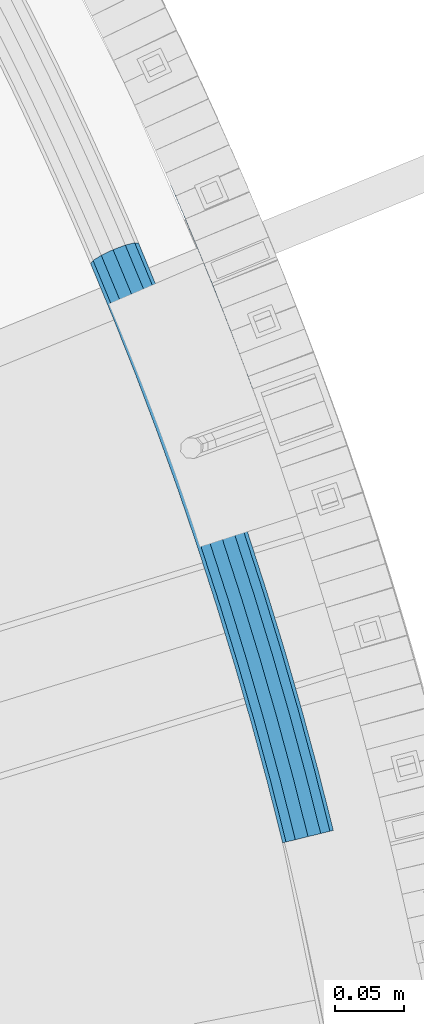
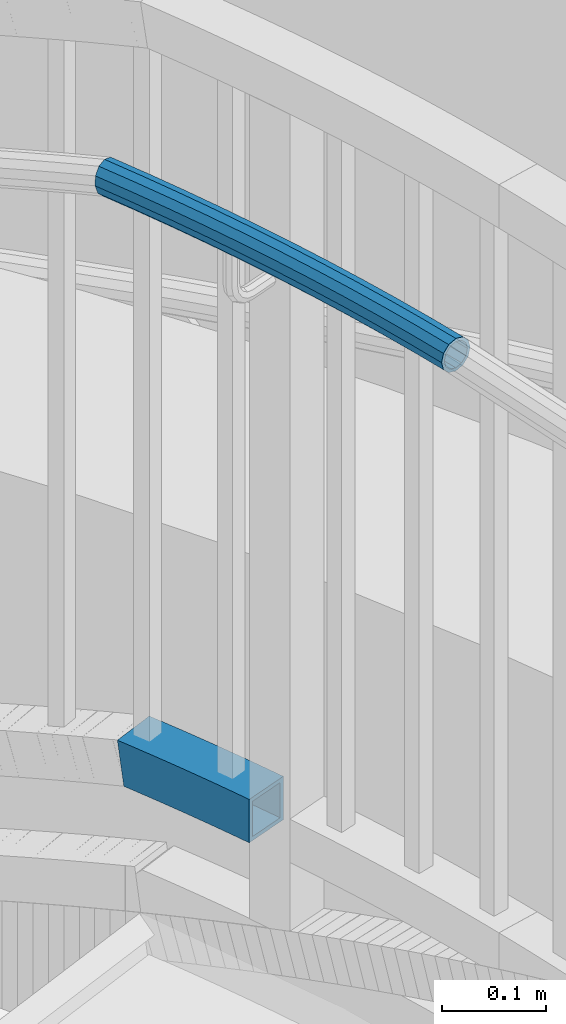
# One storey, part 509 of 975: 2 beams.
"""IFC2X3 building model written with IfcOpenShell, lengths in millimetres."""

from ifc_helpers import new_model, si_unit, frame, origin_with_axes, place, context, subcontext, project, spatial, faceted_brep, material, type_object, element, save


model = new_model("IFC2X3")

# Units and contexts
model_context = context("Model", 3, precision=1e-05, world=origin_with_axes())
body_context = subcontext(model_context, "Body", "Model", "MODEL_VIEW")
ifc_project = project(units=[si_unit("LENGTHUNIT", "METRE", prefix="MILLI"), si_unit("AREAUNIT", "SQUARE_METRE"), si_unit("VOLUMEUNIT", "CUBIC_METRE"), si_unit("MASSUNIT", "GRAM", prefix="KILO"), si_unit("TIMEUNIT", "SECOND"), si_unit("PLANEANGLEUNIT", "RADIAN"), si_unit("SOLIDANGLEUNIT", "STERADIAN"), si_unit("THERMODYNAMICTEMPERATUREUNIT", "DEGREE_CELSIUS"), si_unit("LUMINOUSINTENSITYUNIT", "LUMEN")], contexts=[model_context])

# Site, building, storey
site_placement = place(None, origin_with_axes())
site = spatial("IfcSite", under=ifc_project, at=site_placement, CompositionType="ELEMENT")
building_placement = place(site_placement, origin_with_axes())
building = spatial("IfcBuilding", under=site, at=building_placement, Name="Undefined", CompositionType="ELEMENT")
storey_placement = place(building_placement, origin_with_axes())
storey = spatial("IfcBuildingStorey", under=building, at=storey_placement, Name="Undefined", CompositionType="ELEMENT", Elevation=0.0)

# Beams
ifc_material = material()
beam_type_1 = type_object("IfcBeamType", PredefinedType="NOTDEFINED")
beam_1_placement = place(storey_placement, frame((37300.2363106744, 4493.54942107497, 3028.95), z_axis=(0.0, 0.0, 1.0), x_axis=(0.315248531112646, -0.949009148339108, 0.0)))
element("IfcBeam", 1, at=beam_1_placement, inside=storey, type_object=beam_type_1, material=ifc_material, Name="HANDRAIL", context=body_context, shape_type="Brep", body=[
    faceted_brep([(43.9662384109333, 19.7516310923238, -9.52500000000009), (44.4177076830847, 12.7934782196535, -16.4977839420935), (4.88784464295168, 9.90696300108539, -16.4977839420935), (3.21381363590353, 16.7758430358954, -9.52500000000009), (43.8009891883012, 22.2984918071379, 0.0), (1.49115918698317, 19.2089802631526, 0.0), (43.9662384109333, 19.7516310923238, 9.52500000000009), (0.181465164617293, 16.5544175277537, 9.52500000000009), (44.4177076830847, 12.7934782196535, 16.4977839420935), (-0.364336975573679, 9.52344277088559, 16.4977839420935), (45.034426177871, 3.2884646321836, 19.0500000000002), (-3.63797880709171e-12, 3.63797880709171e-12, 19.0500000000002), (45.6511446726563, -6.21654895529355, 16.4977839420935), (1.17685231783889, -9.46411198346323, 16.4977839420935), (46.1026139448077, -13.1747018279639, 9.52500000000009), (2.85088332488613, -16.3329920182732, 9.52500000000009), (46.2678631674435, -15.7215625427707, 0.0), (4.57353777380649, -18.7661292455377, 0.0), (46.1026139448077, -13.1747018279639, -9.52500000000009), (5.88323179617146, -16.1115665101388, -9.52500000000009), (45.6511446726563, -6.21654895529355, -16.4977839420935), (6.42903393636243, -9.08059175326343, -16.4977839420935), (45.034426177871, 3.2884646321836, -19.0500000000002), (6.06469695168289, 0.442851016952773, -19.0500000000002), (89.6535286661638, 15.3608104653613, -16.4977839420935), (90.1162091780316, 5.84705454333744, -19.0500000000002), (90.5788896899039, -3.66670137867914, -16.4977839420935), (90.9175953322629, -10.6312540844083, -9.52500000000009), (91.0415702017717, -13.180457300703, 0.0), (90.9175953322629, -10.6312540844083, 9.52500000000009), (90.5788896899039, -3.66670137867914, 16.4977839420935), (90.1162091780316, 5.84705454333744, 19.0500000000002), (89.6535286661638, 15.3608104653613, 16.4977839420935), (89.314823023803, 22.3253631710977, 9.52500000000009), (89.1908481542932, 24.8745663873851, 0.0), (89.314823023803, 22.3253631710977, -9.52500000000009), (134.699146393385, 24.1642257241328, -9.52500000000009), (134.92499953809, 17.1951005092851, -16.4977839420935), (135.23352067128, 7.67509842366417, -19.0500000000002), (135.542041804473, -1.84490366196405, -16.4977839420935), (135.767894949178, -8.81402887678996, -9.52500000000009), (135.850562937663, -11.364905747585, 0.0), (135.767894949178, -8.81402887678996, 9.52500000000009), (135.542041804473, -1.84490366196405, 16.4977839420935), (135.23352067128, 7.67509842366417, 19.0500000000002), (134.92499953809, 17.1951005092851, 16.4977839420935), (134.699146393385, 24.1642257241328, 9.52500000000009), (134.6164784049, 26.7151025949133, 0.0), (180.065961394015, 27.8196175191697, 0.0), (180.107300811473, 25.2677362800023, -9.52500000000009), (180.220242200318, 18.2958670797234, -16.4977839420935), (180.374523006625, 8.77211664028437, -19.0500000000002), (180.52880381293, -0.751633799154661, -16.4977839420935), (180.641745201778, -7.72350299943355, -9.52500000000009), (180.683084619236, -10.2753842385937, 0.0), (180.641745201778, -7.72350299943355, 9.52500000000009), (180.52880381293, -0.751633799154661, 16.4977839420935), (180.374523006625, 8.77211664028437, 19.0500000000002), (180.220242200318, 18.2958670797234, 16.4977839420935), (180.107300811473, 25.2677362800023, 9.52500000000009), (225.527372317183, 25.6356053052223, 9.52500000000009), (225.527372317182, 28.187821363128, 0.0), (225.527372317183, 25.6356053052223, -9.52500000000009), (225.527372317186, 18.6628213631193, -16.4977839420935), (225.52737231719, 9.13782136313239, -19.0500000000002), (225.527372317194, -0.387178636869066, -16.4977839420935), (225.5273723172, -7.35996257895749, -9.52500000000009), (225.5273723172, -9.91217863685597, 0.0), (225.5273723172, -7.35996257895749, 9.52500000000009), (225.527372317194, -0.387178636869066, 16.4977839420935), (225.52737231719, 9.13782136313239, 19.0500000000002), (225.527372317186, 18.6628213631193, 16.4977839420935), (270.834502434054, 18.295867079898, 16.4977839420935), (270.947443822894, 25.2677362801696, 9.52500000000009), (270.988783240348, 27.8196175193298, 0.0), (270.947443822894, 25.2677362801696, -9.52500000000009), (270.834502434054, 18.295867079898, -16.4977839420935), (270.680221627757, 8.77211664045899, -19.0500000000002), (270.525940821462, -0.751633798980038, -16.4977839420935), (270.41299943262, -7.7235029992662, -9.52500000000009), (270.371660015167, -10.2753842384263, 0.0), (270.41299943262, -7.7235029992662, 9.52500000000009), (270.525940821462, -0.751633798980038, 16.4977839420935), (270.680221627757, 8.77211664045899, 19.0500000000002), (315.821223963102, 7.67509842401341, 19.0500000000002), (316.129745096284, 17.1951005096416, 16.4977839420935), (316.355598240983, 24.1642257244748, 9.52500000000009), (316.438266229466, 26.7151025952626, 0.0), (316.355598240983, 24.1642257244748, -9.52500000000009), (316.129745096284, 17.1951005096416, -16.4977839420935), (315.821223963102, 7.67509842401341, -19.0500000000002), (315.51270282992, -1.84490366161481, -16.4977839420935), (315.286849685222, -8.81402887645527, -9.52500000000009), (315.204181696738, -11.364905747243, 0.0), (315.286849685222, -8.81402887645527, 9.52500000000009), (315.51270282992, -1.84490366161481, 16.4977839420935), (360.475854944491, -3.66670137816982, 16.4977839420935), (360.938535456352, 5.8470545438613, 19.0500000000002), (361.401215968212, 15.3608104658852, 16.4977839420935), (361.739921610567, 22.3253631716143, 9.52500000000009), (361.863896480075, 24.8745663879163, 0.0), (361.739921610567, 22.3253631716143, -9.52500000000009), (361.401215968212, 15.3608104658852, -16.4977839420935), (360.938535456352, 5.8470545438613, -19.0500000000002), (360.475854944491, -3.66670137816982, -16.4977839420935), (360.137149302138, -10.6312540838917, -9.52500000000009), (360.013174432632, -13.1804573001864, 0.0), (360.137149302138, -10.6312540838917, 9.52500000000009), (404.952130689596, -13.1747018272727, 9.52500000000009), (405.40359996174, -6.21654895460961, 16.4977839420935), (406.020318456517, 3.28846463287482, 19.0500000000002), (406.637036951293, 12.793478220352, 16.4977839420935), (407.088506223437, 19.751631093015, 9.52500000000009), (407.25375544607, 22.2984918078291, 0.0), (407.088506223437, 19.751631093015, -9.52500000000009), (406.637036951293, 12.793478220352, -16.4977839420935), (406.020318456517, 3.28846463287482, -19.0500000000002), (405.40359996174, -6.21654895460961, -16.4977839420935), (404.952130689596, -13.1747018272727, -9.52500000000009), (404.786881466963, -15.7215625420868, 0.0), (449.513555301939, -18.9875547506308, 0.0), (449.720035520446, -16.4437047696847, 9.52500000000009), (450.284149968164, -9.49377737488248, 16.4977839420935), (451.054744634393, 8.65838956087828e-10, 19.0500000000002), (451.825339300621, 9.49377737662144, 16.4977839420935), (452.38945374834, 16.4437047714164, 9.52500000000009), (452.595933966847, 18.9875547523698, 0.0), (452.38945374834, 16.4437047714164, -9.52500000000009), (451.825339300621, 9.49377737662144, -16.4977839420935), (451.054744634393, 8.65838956087828e-10, -19.0500000000002), (450.284149968164, -9.49377737488248, -16.4977839420935), (449.720035520446, -16.4437047696847, -9.52500000000009), (45.896097643199, -9.99182297899824, -7.68350000000009), (46.0293986827919, -12.046290622282, 0.0), (90.862667070518, -9.50180501085561, 0.0), (90.7626606757785, -7.44544774971291, -7.68350000000009), (135.731268099496, -7.68383827447542, 0.0), (135.664582588784, -5.62613093203254, -7.68350000000009), (180.62342937413, -6.59286740201787, 0.0), (180.59008224405, -4.53434986908542, -7.68350000000009), (225.527372317198, -6.22917863686598, 0.0), (225.527372317197, -4.17039101682167, -7.68350000000009), (270.431315260268, -6.59286740183597, 0.0), (270.464662390348, -4.53434986891079, -7.68350000000009), (315.323476534903, -7.68383827412617, 0.0), (315.390162045612, -5.62613093169784, -7.68350000000009), (360.192077563884, -9.50180501033901, 0.0), (360.29208395862, -7.44544774919632, -7.68350000000009), (405.158646991201, -9.99182297830703, -7.68350000000009), (405.025345951611, -12.0462906215835, 0.0), (449.81151857288, -15.3166274986797, 0.0), (449.978079282476, -13.2645885140373, -7.68350000000009), (360.29208395862, -7.44544774919632, 7.68350000000009), (405.158646991201, -9.99182297830703, 7.68350000000009), (315.390162045612, -5.62613093169784, 7.68350000000009), (270.464662390348, -4.53434986891079, 7.68350000000009), (225.527372317197, -4.17039101682167, 7.68350000000009), (180.59008224405, -4.53434986908542, 7.68350000000009), (135.664582588784, -5.62613093203254, 7.68350000000009), (90.7626606757785, -7.44544774971291, 7.68350000000009), (45.896097643199, -9.99182297899824, 7.68350000000009), (45.5319124303314, -4.37891299505281, 13.3082123799554), (90.489438124273, -1.82737523376272, 13.3082123799554), (135.482394385389, -0.00436992540198844, 13.3082123799554), (180.498976190377, 1.08962461914052, 13.3082123799554), (225.527372317193, 1.4543213631332, 13.3082123799554), (270.555768444013, 1.08962461930787, 13.3082123799554), (315.572350249003, -0.00436992506001843, 13.3082123799554), (360.565306510119, -1.82737523324613, 13.3082123799554), (405.522832204065, -4.37891299435432, 13.3082123799554), (360.938535456352, 5.8470545438613, 15.3670000000002), (406.020318456517, 3.28846463287482, 15.3670000000002), (315.821223963102, 7.67509842401341, 15.3670000000002), (270.680221627757, 8.77211664045899, 15.3670000000002), (225.52737231719, 9.13782136313239, 15.3670000000002), (180.374523006625, 8.77211664028437, 15.3670000000002), (135.23352067128, 7.67509842366417, 15.3670000000002), (90.1162091780316, 5.84705454333744, 15.3670000000002), (45.034426177871, 3.2884646321836, 15.3670000000002), (44.5369399254096, 10.9558422594055, 13.3082123799554), (89.7429802317911, 13.5214843204376, 13.3082123799554), (134.984646957176, 15.3545667727376, 13.3082123799554), (180.250069822872, 16.4546086614282, 13.3082123799554), (225.527372317187, 16.8213213631243, 13.3082123799554), (270.804674811504, 16.4546086616101, 13.3082123799554), (316.070097677202, 15.3545667730796, 13.3082123799554), (361.311764402586, 13.5214843209615, 13.3082123799554), (406.517804708972, 10.9558422601112, 13.3082123799554), (361.584986954084, 19.1395568369117, 7.68350000000009), (406.881989921833, 16.5687522440494, 7.68350000000009), (316.252285880592, 20.9763277797247, 7.68350000000009), (270.895780865169, 22.0785831498288, 7.68350000000009), (225.527372317184, 22.4460337430792, 7.68350000000009), (180.158963769201, 22.0785831496542, 7.68350000000009), (134.802458753778, 20.9763277793681, 7.68350000000009), (89.4697576802873, 19.1395568363951, 7.68350000000009), (44.172754712542, 16.5687522433509, 7.68350000000009), (44.0394536729491, 18.6232198866419, 0.0), (89.3697512855506, 21.195914097545, 0.0), (134.735773243067, 23.0340351218038, 0.0), (180.125616639119, 24.1371006825793, 0.0), (225.527372317186, 24.5048213631235, 0.0), (270.929127995248, 24.137100682754, 0.0), (316.318971391301, 23.0340351221457, 0.0), (361.684993348822, 21.1959140980689, 0.0), (407.015290961423, 18.6232198873404, 0.0), (361.584986954084, 19.1395568369117, -7.68350000000009), (406.881989921833, 16.5687522440494, -7.68350000000009), (316.252285880592, 20.9763277797247, -7.68350000000009), (270.895780865169, 22.0785831498288, -7.68350000000009), (225.527372317184, 22.4460337430792, -7.68350000000009), (180.158963769201, 22.0785831496542, -7.68350000000009), (134.802458753778, 20.9763277793681, -7.68350000000009), (89.4697576802873, 19.1395568363951, -7.68350000000009), (44.172754712542, 16.5687522433509, -7.68350000000009), (44.5369399254096, 10.9558422594055, -13.3082123799554), (89.7429802317911, 13.5214843204376, -13.3082123799554), (134.984646957176, 15.3545667727376, -13.3082123799554), (180.250069822872, 16.4546086614282, -13.3082123799554), (225.527372317187, 16.8213213631243, -13.3082123799554), (270.804674811504, 16.4546086616101, -13.3082123799554), (316.070097677202, 15.3545667730796, -13.3082123799554), (361.311764402586, 13.5214843209615, -13.3082123799554), (406.517804708972, 10.9558422601112, -13.3082123799554), (360.938535456352, 5.8470545438613, -15.3670000000002), (406.020318456517, 3.28846463287482, -15.3670000000002), (315.821223963102, 7.67509842401341, -15.3670000000002), (270.680221627757, 8.77211664045899, -15.3670000000002), (225.52737231719, 9.13782136313239, -15.3670000000002), (180.374523006625, 8.77211664028437, -15.3670000000002), (135.23352067128, 7.67509842366417, -15.3670000000002), (90.1162091780316, 5.84705454333744, -15.3670000000002), (45.034426177871, 3.2884646321836, -15.3670000000002), (45.5319124303314, -4.37891299505281, -13.3082123799554), (90.489438124273, -1.82737523376272, -13.3082123799554), (135.482394385389, -0.00436992540198844, -13.3082123799554), (180.498976190377, 1.08962461914052, -13.3082123799554), (225.527372317193, 1.4543213631332, -13.3082123799554), (270.555768444013, 1.08962461930787, -13.3082123799554), (315.572350249003, -0.00436992506001843, -13.3082123799554), (360.565306510119, -1.82737523324613, -13.3082123799554), (405.522832204065, -4.37891299435432, -13.3082123799554), (450.433131603636, -7.65831374890695, -13.3082123799554), (451.054744634393, 8.65838956087828e-10, -15.3670000000002), (451.67635766515, 7.6583137506459, -13.3082123799554), (452.131409986309, 13.2645885157763, -7.68350000000009), (452.297970695906, 15.3166275004114, 0.0), (452.131409986309, 13.2645885157763, 7.68350000000009), (451.67635766515, 7.6583137506459, 13.3082123799554), (451.054744634393, 8.65838956087828e-10, 15.3670000000002), (450.433131603636, -7.65831374890695, 13.3082123799554), (449.978079282476, -13.2645885140373, 7.68350000000009), (5.77234141487406, -7.28220174927264, -13.3082123799554), (5.33206102179065, -12.9538547198026, -7.68350000000009), (4.27557451041412, -15.0952019930337, 0.0), (2.88596658828465, -13.1324712963687, 7.68350000000009), (1.53558157593307, -7.59157473495725, 13.3082123799554), (0.586254046889735, 0.0428089322449523, 15.3670000000002), (0.292355545914688, 7.72505276688753, 13.3082123799554), (0.732635939001739, 13.3967057374248, 7.68350000000009), (1.78912245037736, 15.5380530106413, 0.0), (3.17873037250592, 13.5753223139909, -7.68350000000009), (4.5291153848566, 8.03442575257213, -13.3082123799554), (5.47844291389902, 0.400042085369932, -15.3670000000002)], [[[0, 1, 2, 3]], [[4, 0, 3, 5]], [[6, 4, 5, 7]], [[8, 6, 7, 9]], [[10, 8, 9, 11]], [[12, 10, 11, 13]], [[14, 12, 13, 15]], [[16, 14, 15, 17]], [[18, 16, 17, 19]], [[20, 18, 19, 21]], [[22, 20, 21, 23]], [[1, 22, 23, 2]], [[22, 1, 24, 25]], [[20, 22, 25, 26]], [[18, 20, 26, 27]], [[16, 18, 27, 28]], [[14, 16, 28, 29]], [[12, 14, 29, 30]], [[10, 12, 30, 31]], [[8, 10, 31, 32]], [[6, 8, 32, 33]], [[4, 6, 33, 34]], [[0, 4, 34, 35]], [[1, 0, 35, 24]], [[24, 35, 36, 37]], [[25, 24, 37, 38]], [[26, 25, 38, 39]], [[27, 26, 39, 40]], [[28, 27, 40, 41]], [[29, 28, 41, 42]], [[30, 29, 42, 43]], [[31, 30, 43, 44]], [[32, 31, 44, 45]], [[33, 32, 45, 46]], [[34, 33, 46, 47]], [[35, 34, 47, 36]], [[36, 47, 48, 49]], [[37, 36, 49, 50]], [[38, 37, 50, 51]], [[39, 38, 51, 52]], [[40, 39, 52, 53]], [[41, 40, 53, 54]], [[42, 41, 54, 55]], [[43, 42, 55, 56]], [[44, 43, 56, 57]], [[45, 44, 57, 58]], [[46, 45, 58, 59]], [[47, 46, 59, 48]], [[48, 59, 60, 61]], [[49, 48, 61, 62]], [[50, 49, 62, 63]], [[51, 50, 63, 64]], [[52, 51, 64, 65]], [[53, 52, 65, 66]], [[54, 53, 66, 67]], [[55, 54, 67, 68]], [[56, 55, 68, 69]], [[57, 56, 69, 70]], [[58, 57, 70, 71]], [[59, 58, 71, 60]], [[60, 71, 72, 73]], [[61, 60, 73, 74]], [[62, 61, 74, 75]], [[63, 62, 75, 76]], [[64, 63, 76, 77]], [[65, 64, 77, 78]], [[66, 65, 78, 79]], [[67, 66, 79, 80]], [[68, 67, 80, 81]], [[69, 68, 81, 82]], [[70, 69, 82, 83]], [[71, 70, 83, 72]], [[72, 83, 84, 85]], [[73, 72, 85, 86]], [[74, 73, 86, 87]], [[75, 74, 87, 88]], [[76, 75, 88, 89]], [[77, 76, 89, 90]], [[78, 77, 90, 91]], [[79, 78, 91, 92]], [[80, 79, 92, 93]], [[81, 80, 93, 94]], [[82, 81, 94, 95]], [[83, 82, 95, 84]], [[84, 95, 96, 97]], [[85, 84, 97, 98]], [[86, 85, 98, 99]], [[87, 86, 99, 100]], [[88, 87, 100, 101]], [[89, 88, 101, 102]], [[90, 89, 102, 103]], [[91, 90, 103, 104]], [[92, 91, 104, 105]], [[93, 92, 105, 106]], [[94, 93, 106, 107]], [[95, 94, 107, 96]], [[96, 107, 108, 109]], [[97, 96, 109, 110]], [[98, 97, 110, 111]], [[99, 98, 111, 112]], [[100, 99, 112, 113]], [[101, 100, 113, 114]], [[102, 101, 114, 115]], [[103, 102, 115, 116]], [[104, 103, 116, 117]], [[105, 104, 117, 118]], [[106, 105, 118, 119]], [[107, 106, 119, 108]], [[108, 119, 120, 121]], [[109, 108, 121, 122]], [[110, 109, 122, 123]], [[111, 110, 123, 124]], [[112, 111, 124, 125]], [[113, 112, 125, 126]], [[114, 113, 126, 127]], [[115, 114, 127, 128]], [[116, 115, 128, 129]], [[117, 116, 129, 130]], [[118, 117, 130, 131]], [[119, 118, 131, 120]], [[132, 133, 134, 135]], [[135, 134, 136, 137]], [[137, 136, 138, 139]], [[139, 138, 140, 141]], [[141, 140, 142, 143]], [[143, 142, 144, 145]], [[145, 144, 146, 147]], [[148, 149, 150, 151]], [[147, 146, 149, 148]], [[146, 152, 153, 149]], [[144, 154, 152, 146]], [[142, 155, 154, 144]], [[140, 156, 155, 142]], [[138, 157, 156, 140]], [[136, 158, 157, 138]], [[134, 159, 158, 136]], [[133, 160, 159, 134]], [[160, 161, 162, 159]], [[159, 162, 163, 158]], [[158, 163, 164, 157]], [[157, 164, 165, 156]], [[156, 165, 166, 155]], [[155, 166, 167, 154]], [[154, 167, 168, 152]], [[152, 168, 169, 153]], [[168, 170, 171, 169]], [[167, 172, 170, 168]], [[166, 173, 172, 167]], [[165, 174, 173, 166]], [[164, 175, 174, 165]], [[163, 176, 175, 164]], [[162, 177, 176, 163]], [[161, 178, 177, 162]], [[178, 179, 180, 177]], [[177, 180, 181, 176]], [[176, 181, 182, 175]], [[175, 182, 183, 174]], [[174, 183, 184, 173]], [[173, 184, 185, 172]], [[172, 185, 186, 170]], [[170, 186, 187, 171]], [[186, 188, 189, 187]], [[185, 190, 188, 186]], [[184, 191, 190, 185]], [[183, 192, 191, 184]], [[182, 193, 192, 183]], [[181, 194, 193, 182]], [[180, 195, 194, 181]], [[179, 196, 195, 180]], [[196, 197, 198, 195]], [[195, 198, 199, 194]], [[194, 199, 200, 193]], [[193, 200, 201, 192]], [[192, 201, 202, 191]], [[191, 202, 203, 190]], [[190, 203, 204, 188]], [[188, 204, 205, 189]], [[204, 206, 207, 205]], [[203, 208, 206, 204]], [[202, 209, 208, 203]], [[201, 210, 209, 202]], [[200, 211, 210, 201]], [[199, 212, 211, 200]], [[198, 213, 212, 199]], [[197, 214, 213, 198]], [[214, 215, 216, 213]], [[213, 216, 217, 212]], [[212, 217, 218, 211]], [[211, 218, 219, 210]], [[210, 219, 220, 209]], [[209, 220, 221, 208]], [[208, 221, 222, 206]], [[206, 222, 223, 207]], [[222, 224, 225, 223]], [[221, 226, 224, 222]], [[220, 227, 226, 221]], [[219, 228, 227, 220]], [[218, 229, 228, 219]], [[217, 230, 229, 218]], [[216, 231, 230, 217]], [[215, 232, 231, 216]], [[232, 233, 234, 231]], [[231, 234, 235, 230]], [[230, 235, 236, 229]], [[229, 236, 237, 228]], [[228, 237, 238, 227]], [[227, 238, 239, 226]], [[226, 239, 240, 224]], [[224, 240, 241, 225]], [[225, 241, 242, 243]], [[223, 225, 243, 244]], [[207, 223, 244, 245]], [[205, 207, 245, 246]], [[189, 205, 246, 247]], [[187, 189, 247, 248]], [[171, 187, 248, 249]], [[169, 171, 249, 250]], [[153, 169, 250, 251]], [[149, 153, 251, 150]], [[130, 129, 128, 127, 126, 125, 124, 123, 122, 121, 120, 131], [250, 249, 248, 247, 246, 245, 244, 243, 242, 151, 150, 251]], [[241, 148, 151, 242]], [[240, 147, 148, 241]], [[239, 145, 147, 240]], [[238, 143, 145, 239]], [[237, 141, 143, 238]], [[236, 139, 141, 237]], [[235, 137, 139, 236]], [[234, 135, 137, 235]], [[233, 132, 135, 234]], [[132, 233, 252, 253]], [[133, 132, 253, 254]], [[160, 133, 254, 255]], [[161, 160, 255, 256]], [[178, 161, 256, 257]], [[179, 178, 257, 258]], [[196, 179, 258, 259]], [[197, 196, 259, 260]], [[214, 197, 260, 261]], [[215, 214, 261, 262]], [[232, 215, 262, 263]], [[233, 232, 263, 252]], [[17, 15, 13, 11, 9, 7, 5, 3, 2, 23, 21, 19], [262, 261, 260, 259, 258, 257, 256, 255, 254, 253, 252, 263]]]),
])
beam_type_2 = type_object("IfcBeamType", Name="HSS2X2X.188_TUBES", PredefinedType="NOTDEFINED")
beam_2_placement = place(storey_placement, frame((37355.8605747399, 4572.69146770038, 2298.70000076294), z_axis=(0.0, 0.0, 1.0), x_axis=(0.373084706878614, -0.927797284698171, 0.0)))
element("IfcBeam", 2, at=beam_2_placement, inside=storey, type_object=beam_type_2, material=ifc_material, Name="HANDRAIL", ObjectType="HSS2X2X.188_TUBES", context=body_context, shape_type="Brep", body=[
    faceted_brep([(147.456720800585, -23.7531655992279, 25.4000000000001), (147.456720800585, -23.7531655992279, -25.4000000000001), (168.387492684789, -24.1411430651133, -25.4000000000001), (168.387492684789, -24.1411430651133, 25.4000000000001), (126.523647813892, -23.5203705898093, 25.4000000000001), (126.523647813892, -23.5203705898093, -25.4000000000001), (105.589424244334, -23.4427708316798, 25.4000000000001), (105.589424244334, -23.4427708316798, -25.4000000000001), (84.6552006747788, -23.520370589853, 25.4000000000001), (84.6552006747788, -23.520370589853, -25.4000000000001), (63.7221276880864, -23.7531655993298, 25.4000000000001), (63.7221276880864, -23.7531655993298, -25.4000000000001), (42.7913558038817, -24.1411430652588, 25.4000000000001), (42.7913558038817, -24.1411430652588, -25.4000000000001), (41.6616101529416, 26.6462931248097, 25.4000000000001), (41.6616101529416, 26.6462931248097, -25.4000000000001), (30.8638112599128, 26.3660517346943, -25.4000000000001), (23.1182605788654, 26.1650270711107, 25.4000000000001), (62.9689294229884, 27.0412503572443, 25.4000000000001), (62.9689294229884, 27.0412503572443, -25.4000000000001), (84.2785911926603, 27.2782333800715, 25.4000000000001), (84.2785911926603, 27.2782333800715, -25.4000000000001), (105.589424244343, 27.3572291682867, 25.4000000000001), (105.589424244343, 27.3572291682867, -25.4000000000001), (126.900257296022, 27.2782333801297, 25.4000000000001), (126.900257296022, 27.2782333801297, -25.4000000000001), (148.209919065697, 27.0412503573461, 25.4000000000001), (148.209919065697, 27.0412503573461, -25.4000000000001), (169.517238335744, 26.6462931249625, 25.4000000000001), (169.517238335744, 26.6462931249625, -25.4000000000001), (186.699680473053, 26.200347472768, 25.4000000000001), (186.699680473053, 26.200347472768, -25.4000000000001), (31.8430519983904, -24.425290594605, -25.4000000000001), (184.850509059865, -24.568417053044, -25.4000000000001), (184.850509059865, -24.568417053044, 25.4000000000001), (24.0975013173429, -24.626315258196, 25.4000000000001), (147.527333137938, -18.9911891033044, -20.6374999999998), (147.527333137938, -18.9911891033044, 20.6374999999998), (168.493406339565, -19.3798209222878, 20.6374999999998), (168.493406339565, -19.3798209222878, -20.6374999999998), (126.558954952839, -18.758001467635, -20.6374999999998), (126.558954952839, -18.758001467635, 20.6374999999998), (105.589424244337, -18.6802708316754, -20.6374999999998), (105.589424244337, -18.6802708316754, 20.6374999999998), (84.6198935358279, -18.7580014676787, -20.6374999999998), (84.6198935358279, -18.7580014676787, 20.6374999999998), (63.6515153507335, -18.9911891034062, -20.6374999999998), (63.6515153507335, -18.9911891034062, 20.6374999999998), (42.6854421491043, -19.3798209224406, -20.6374999999998), (42.6854421491043, -19.3798209224406, 20.6374999999998), (31.0251028028106, -19.6824483134478, -20.6374999999998), (24.7318428744566, -19.8457808526146, 20.6374999999998), (23.9362097744452, 21.4221847899535, 20.6374999999998), (30.2294697027955, 21.5855173291129, -20.6374999999998), (41.7675238077154, 21.8849709819842, -20.6374999999998), (41.7675238077154, 21.8849709819842, 20.6374999999998), (63.0395417603413, 22.2792738613207, -20.6374999999998), (63.0395417603413, 22.2792738613207, 20.6374999999998), (84.3138983316112, 22.5158642578899, -20.6374999999998), (84.3138983316112, 22.5158642578899, 20.6374999999998), (105.589424244345, 22.5947291682896, -20.6374999999998), (105.589424244345, 22.5947291682896, 20.6374999999998), (126.864950157071, 22.5158642579408, -20.6374999999998), (126.864950157071, 22.5158642579408, 20.6374999999998), (148.139306728342, 22.2792738614153, -20.6374999999998), (148.139306728342, 22.2792738614153, 20.6374999999998), (169.411324680967, 21.8849709821443, -20.6374999999998), (169.411324680967, 21.8849709821443, 20.6374999999998), (186.526320653069, 21.4407757984809, 20.6374999999998), (185.023868879851, -19.8088453787568, 20.6374999999998), (185.023868879851, -19.8088453787568, -20.6374999999998), (186.526320653069, 21.4407757984809, -20.6374999999998)], [[[0, 1, 2, 3]], [[4, 5, 1, 0]], [[6, 7, 5, 4]], [[8, 9, 7, 6]], [[10, 11, 9, 8]], [[12, 13, 11, 10]], [[14, 15, 16, 17]], [[15, 14, 18, 19]], [[19, 18, 20, 21]], [[21, 20, 22, 23]], [[23, 22, 24, 25]], [[25, 24, 26, 27]], [[27, 26, 28, 29]], [[29, 28, 30, 31]], [[2, 1, 5, 7, 9, 11, 13, 32, 16, 15, 19, 21, 23, 25, 27, 29, 31, 33]], [[3, 2, 33, 34]], [[28, 26, 24, 22, 20, 18, 14, 17, 35, 12, 10, 8, 6, 4, 0, 3, 34, 30]], [[13, 12, 35, 32]], [[36, 37, 38, 39]], [[40, 41, 37, 36]], [[42, 43, 41, 40]], [[44, 45, 43, 42]], [[46, 47, 45, 44]], [[48, 49, 47, 46]], [[49, 48, 50, 51]], [[17, 16, 32, 35], [52, 51, 50, 53]], [[54, 55, 52, 53]], [[55, 54, 56, 57]], [[57, 56, 58, 59]], [[59, 58, 60, 61]], [[61, 60, 62, 63]], [[63, 62, 64, 65]], [[65, 64, 66, 67]], [[38, 37, 41, 43, 45, 47, 49, 51, 52, 55, 57, 59, 61, 63, 65, 67, 68, 69]], [[39, 38, 69, 70]], [[66, 64, 62, 60, 58, 56, 54, 53, 50, 48, 46, 44, 42, 40, 36, 39, 70, 71]], [[67, 66, 71, 68]], [[33, 31, 30, 34], [70, 69, 68, 71]]]),
])

save(model, "model.ifc")
